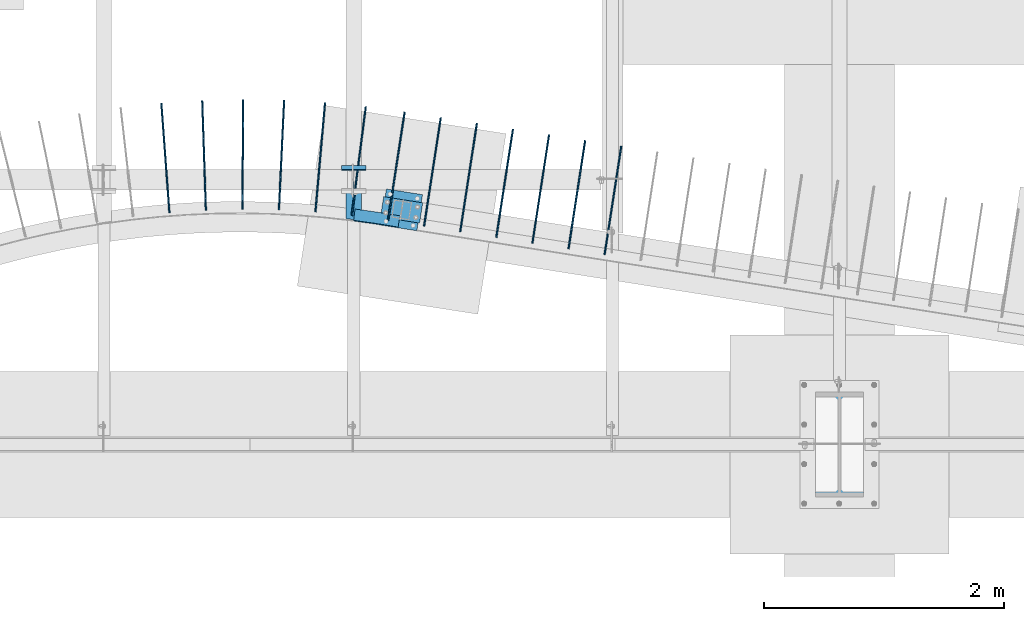
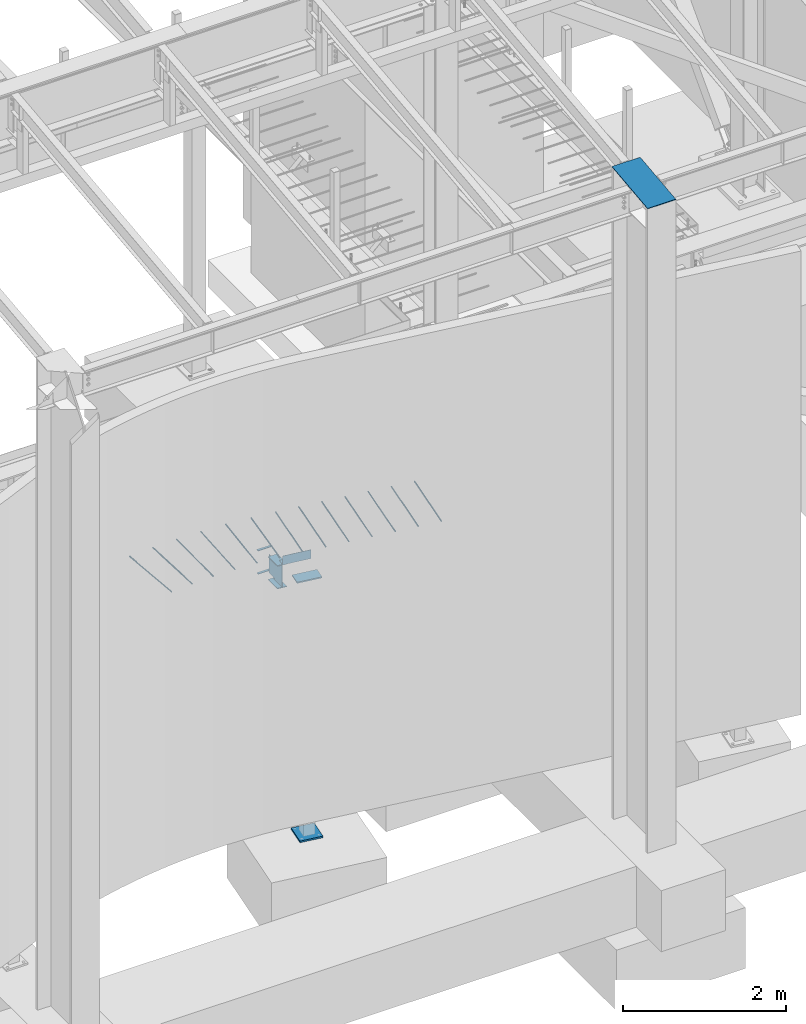
# One storey, part 813 of 1179: 20 beams, 18 elements without a shape of their own.
"""IFC2X3 building model written with IfcOpenShell, lengths in millimetres."""

from ifc_helpers import new_model, si_unit, frame, origin_with_axes, place, context, subcontext, project, spatial, faceted_brep, material, type_object, element, aggregate, save


model = new_model("IFC2X3")

# Units and contexts
model_context = context("Model", 3, precision=1e-05, world=origin_with_axes())
body_context = subcontext(model_context, "Body", "Model", "MODEL_VIEW")
ifc_project = project(units=[si_unit("LENGTHUNIT", "METRE", prefix="MILLI"), si_unit("AREAUNIT", "SQUARE_METRE"), si_unit("VOLUMEUNIT", "CUBIC_METRE"), si_unit("MASSUNIT", "GRAM", prefix="KILO"), si_unit("TIMEUNIT", "SECOND"), si_unit("PLANEANGLEUNIT", "RADIAN"), si_unit("SOLIDANGLEUNIT", "STERADIAN"), si_unit("THERMODYNAMICTEMPERATUREUNIT", "DEGREE_CELSIUS"), si_unit("LUMINOUSINTENSITYUNIT", "LUMEN")], contexts=[model_context])

# Site, building, storey
site_placement = place(None, origin_with_axes())
site = spatial("IfcSite", under=ifc_project, at=site_placement, CompositionType="ELEMENT")
building_placement = place(site_placement, origin_with_axes())
building = spatial("IfcBuilding", under=site, at=building_placement, Name="Undefined", CompositionType="ELEMENT")
storey_placement = place(building_placement, origin_with_axes())
storey = spatial("IfcBuildingStorey", under=building, at=storey_placement, Name="Undefined", CompositionType="ELEMENT", Elevation=0.0)

# Assembly, beams
assembly_1_placement = place(storey_placement, origin_with_axes())
assembly_1 = element("IfcElementAssembly", 1, at=assembly_1_placement, inside=storey, Name="BEAM", AssemblyPlace="NOTDEFINED", PredefinedType="RIGID_FRAME")
ifc_material_1 = material(Name="STEEL/A36")
beam_type_1 = type_object("IfcBeamType", PredefinedType="NOTDEFINED")
beam_1_placement = place(assembly_1_placement, frame((12407.9, 2733.675, 3831.8280002594), z_axis=(-1.0, 0.0, 0.0), x_axis=(0.0, 1.0, 0.0)))
beam_1 = element("IfcBeam", 2, at=beam_1_placement, type_object=beam_type_1, material=ifc_material_1, Name="PLATE", context=body_context, shape_type="Brep", body=[
    faceted_brep([(0.0, 4.76250000000073, -101.6), (0.0, 4.76250000000073, 101.6), (31.75, 4.76249999999982, 101.6), (31.75, 4.76249999999982, -101.6), (0.0, -4.76250000000073, 101.6), (31.75, -4.76249999999982, 101.6), (0.0, -4.76250000000073, -101.6), (31.75, -4.76249999999982, -101.6)], [[[0, 1, 2, 3]], [[1, 4, 5, 2]], [[4, 6, 7, 5]], [[6, 0, 3, 7]], [[5, 7, 3, 2]], [[6, 4, 1, 0]]]),
])
beam_2_placement = place(assembly_1_placement, frame((12407.9, 2722.56287437001, 3490.9125), z_axis=(-1.0, 0.0, 0.0), x_axis=(0.0, 1.0, 0.0)))
beam_2 = element("IfcBeam", 3, at=beam_2_placement, type_object=beam_type_1, material=ifc_material_1, Name="PLATE", context=body_context, shape_type="Brep", body=[
    faceted_brep([(0.0, 4.76250000000073, -101.6), (0.0, 4.76250000000073, 101.6), (31.75, 4.76249999999982, 101.6), (31.75, 4.76249999999982, -101.6), (0.0, -4.76250000000073, 101.6), (31.75, -4.76249999999982, 101.6), (0.0, -4.76250000000073, -101.6), (31.75, -4.76249999999982, -101.6)], [[[0, 1, 2, 3]], [[1, 4, 5, 2]], [[4, 6, 7, 5]], [[6, 0, 3, 7]], [[5, 7, 3, 2]], [[6, 4, 1, 0]]]),
])
aggregate(assembly_1, [beam_1, beam_2])

# Assembly, beam
assembly_2_placement = place(storey_placement, origin_with_axes())
assembly_2 = element("IfcElementAssembly", 4, at=assembly_2_placement, inside=storey, Name="COLUMN", AssemblyPlace="NOTDEFINED", PredefinedType="RIGID_FRAME")
beam_type_2 = type_object("IfcBeamType", PredefinedType="NOTDEFINED")
beam_3_placement = place(assembly_2_placement, frame((16459.2, 876.834752967023, 9341.1779874812), z_axis=(1.0, 0.0, 0.0), x_axis=(0.0, -0.993676146336441, -0.112284087038017)))
beam_3 = element("IfcBeam", 5, at=beam_3_placement, type_object=beam_type_2, material=ifc_material_1, Name="PLATE", context=body_context, shape_type="Brep", body=[
    faceted_brep([(1.07631237348505, 4.76249999999709, -200.025), (1.07631237348505, 4.76249999999709, 200.025), (882.953172586766, 4.762499999586, 200.025), (882.953172586766, 4.762499999586, -200.025), (2.52225618169177e-09, -4.76249999999709, 200.025), (881.876860215802, -4.76250000041, 200.025), (2.52225618169177e-09, -4.76249999999709, -200.025), (881.876860215802, -4.76250000041, -200.025)], [[[0, 1, 2, 3]], [[1, 4, 5, 2]], [[4, 6, 7, 5]], [[6, 0, 3, 7]], [[5, 7, 3, 2]], [[6, 4, 1, 0]]]),
])
aggregate(assembly_2, [beam_3])

assembly_3_placement = place(storey_placement, origin_with_axes())
assembly_3 = element("IfcElementAssembly", 6, at=assembly_3_placement, inside=storey, Name="COLUMN", AssemblyPlace="NOTDEFINED", PredefinedType="RIGID_FRAME")
beam_type_3 = type_object("IfcBeamType", PredefinedType="NOTDEFINED")
beam_4_placement = place(assembly_3_placement, frame((12644.5759112125, 2421.41210607514, 3479.8), z_axis=(-0.156378291007964, -0.987697236050313, 0.0), x_axis=(0.987697236050313, -0.156378291007965, 0.0)))
beam_4 = element("IfcBeam", 7, at=beam_4_placement, type_object=beam_type_3, material=ifc_material_1, Name="PLATE", context=body_context, shape_type="Brep", body=[
    faceted_brep([(-7.27595761418343e-11, 9.52500000000009, -85.7249999999858), (7.82165443524718e-11, 9.52500000000009, 85.724999999984), (330.199999998111, 9.52500000000009, 85.7249999999631), (330.199999997958, 9.52500000000009, -85.7250000000067), (7.82165443524718e-11, -9.52500000000009, 85.724999999984), (330.199999998111, -9.52500000000009, 85.7249999999631), (-7.27595761418343e-11, -9.52500000000009, -85.7249999999858), (330.199999997958, -9.52500000000009, -85.7250000000067)], [[[0, 1, 2, 3]], [[1, 4, 5, 2]], [[4, 6, 7, 5]], [[6, 0, 3, 7]], [[5, 7, 3, 2]], [[6, 4, 1, 0]]]),
])

assembly_4_placement = place(storey_placement, origin_with_axes())
assembly_4 = element("IfcElementAssembly", 8, at=assembly_4_placement, inside=storey, Name="#4 DOWEL", AssemblyPlace="NOTDEFINED", PredefinedType="NOTDEFINED")
ifc_material_2 = material(Name="REBAR/A615-40")
beam_type_4 = type_object("IfcBeamType", Name="#4 DOWEL", PredefinedType="NOTDEFINED")
beam_5_placement = place(assembly_4_placement, frame((14500.3334740278, 2022.55347503947, 3943.35000610352), z_axis=(-0.988373645766026, 0.152044520964006, 0.0), x_axis=(0.152044520964006, 0.988373645766026, 0.0)))
beam_5 = element("IfcBeam", 9, at=beam_5_placement, type_object=beam_type_4, material=ifc_material_2, Name="#4 DOWEL", ObjectType="#4 DOWEL", context=body_context, shape_type="Brep", body=[
    faceted_brep([(0.0, -6.34999999999854, 0.0), (0.0, -4.49012806053361, -4.49012806053452), (914.399999999994, -4.49012806053452, -4.49012806042992), (914.399999999994, -6.34999999999991, 1.0550138540566e-10), (0.0, 0.0, -6.34999999999991), (914.399999999994, 0.0, -6.34999999989668), (0.0, 4.49012806053361, -4.49012806053452), (914.399999999994, 4.49012806053452, -4.49012806042992), (0.0, 6.34999999999854, 0.0), (914.399999999994, 6.34999999999991, 1.0550138540566e-10), (0.0, 4.49012806053361, 4.49012806053452), (914.399999999995, 4.49012806053452, 4.49012806064184), (0.0, 0.0, 6.34999999999991), (914.399999999995, 0.0, 6.35000000010768), (0.0, -4.49012806053361, 4.49012806053452), (914.399999999995, -4.49012806053452, 4.49012806064184)], [[[0, 1, 2, 3]], [[1, 4, 5, 2]], [[4, 6, 7, 5]], [[6, 8, 9, 7]], [[8, 10, 11, 9]], [[10, 12, 13, 11]], [[12, 14, 15, 13]], [[14, 0, 3, 15]], [[5, 7, 9, 11, 13, 15, 3, 2]], [[14, 12, 10, 8, 6, 4, 1, 0]]]),
])
aggregate(assembly_4, [beam_5])

assembly_5_placement = place(storey_placement, origin_with_axes())
assembly_5 = element("IfcElementAssembly", 10, at=assembly_5_placement, inside=storey, Name="#4 DOWEL", AssemblyPlace="NOTDEFINED", PredefinedType="NOTDEFINED")
beam_6_placement = place(assembly_5_placement, frame((14199.2720604806, 2070.14617692751, 3943.35000610352), z_axis=(-0.988373645766026, 0.152044520964006, 0.0), x_axis=(0.152044520964006, 0.988373645766026, 0.0)))
beam_6 = element("IfcBeam", 11, at=beam_6_placement, type_object=beam_type_4, material=ifc_material_2, Name="#4 DOWEL", ObjectType="#4 DOWEL", context=body_context, shape_type="Brep", body=[
    faceted_brep([(0.0, -6.34999999999854, 0.0), (0.0, -4.49012806053361, -4.49012806053452), (914.399999999994, -4.49012806053452, -4.49012806042992), (914.399999999994, -6.34999999999991, 1.0550138540566e-10), (0.0, 0.0, -6.34999999999991), (914.399999999994, 0.0, -6.34999999989668), (0.0, 4.49012806053361, -4.49012806053452), (914.399999999994, 4.49012806053452, -4.49012806042992), (0.0, 6.34999999999854, 0.0), (914.399999999994, 6.34999999999991, 1.0550138540566e-10), (0.0, 4.49012806053361, 4.49012806053452), (914.399999999995, 4.49012806053452, 4.49012806064184), (0.0, 0.0, 6.34999999999991), (914.399999999995, 0.0, 6.35000000010768), (0.0, -4.49012806053361, 4.49012806053452), (914.399999999995, -4.49012806053452, 4.49012806064184)], [[[0, 1, 2, 3]], [[1, 4, 5, 2]], [[4, 6, 7, 5]], [[6, 8, 9, 7]], [[8, 10, 11, 9]], [[10, 12, 13, 11]], [[12, 14, 15, 13]], [[14, 0, 3, 15]], [[5, 7, 9, 11, 13, 15, 3, 2]], [[14, 12, 10, 8, 6, 4, 1, 0]]]),
])
aggregate(assembly_5, [beam_6])

assembly_6_placement = place(storey_placement, origin_with_axes())
assembly_6 = element("IfcElementAssembly", 12, at=assembly_6_placement, inside=storey, Name="#4 DOWEL", AssemblyPlace="NOTDEFINED", PredefinedType="NOTDEFINED")
beam_7_placement = place(assembly_6_placement, frame((13898.2106469335, 2117.73887881554, 3943.35000610352), z_axis=(-0.988373645766026, 0.152044520964006, 0.0), x_axis=(0.152044520964006, 0.988373645766026, 0.0)))
beam_7 = element("IfcBeam", 13, at=beam_7_placement, type_object=beam_type_4, material=ifc_material_2, Name="#4 DOWEL", ObjectType="#4 DOWEL", context=body_context, shape_type="Brep", body=[
    faceted_brep([(0.0, -6.34999999999854, 0.0), (0.0, -4.49012806053361, -4.49012806053452), (914.399999999994, -4.49012806053452, -4.49012806042992), (914.399999999994, -6.34999999999991, 1.0550138540566e-10), (0.0, 0.0, -6.34999999999991), (914.399999999994, 0.0, -6.34999999989668), (0.0, 4.49012806053361, -4.49012806053452), (914.399999999994, 4.49012806053452, -4.49012806042992), (0.0, 6.34999999999854, 0.0), (914.399999999994, 6.34999999999991, 1.0550138540566e-10), (0.0, 4.49012806053361, 4.49012806053452), (914.399999999995, 4.49012806053452, 4.49012806064184), (0.0, 0.0, 6.34999999999991), (914.399999999995, 0.0, 6.35000000010768), (0.0, -4.49012806053361, 4.49012806053452), (914.399999999995, -4.49012806053452, 4.49012806064184)], [[[0, 1, 2, 3]], [[1, 4, 5, 2]], [[4, 6, 7, 5]], [[6, 8, 9, 7]], [[8, 10, 11, 9]], [[10, 12, 13, 11]], [[12, 14, 15, 13]], [[14, 0, 3, 15]], [[5, 7, 9, 11, 13, 15, 3, 2]], [[14, 12, 10, 8, 6, 4, 1, 0]]]),
])
aggregate(assembly_6, [beam_7])

assembly_7_placement = place(storey_placement, origin_with_axes())
assembly_7 = element("IfcElementAssembly", 14, at=assembly_7_placement, inside=storey, Name="#4 DOWEL", AssemblyPlace="NOTDEFINED", PredefinedType="NOTDEFINED")
beam_8_placement = place(assembly_7_placement, frame((13597.1492333864, 2165.33158070358, 3943.35000610352), z_axis=(-0.988373645766026, 0.152044520964006, 0.0), x_axis=(0.152044520964006, 0.988373645766026, 0.0)))
beam_8 = element("IfcBeam", 15, at=beam_8_placement, type_object=beam_type_4, material=ifc_material_2, Name="#4 DOWEL", ObjectType="#4 DOWEL", context=body_context, shape_type="Brep", body=[
    faceted_brep([(0.0, -6.34999999999854, 0.0), (0.0, -4.49012806053361, -4.49012806053452), (914.399999999994, -4.49012806053452, -4.49012806042992), (914.399999999994, -6.34999999999991, 1.0550138540566e-10), (0.0, 0.0, -6.34999999999991), (914.399999999994, 0.0, -6.34999999989668), (0.0, 4.49012806053361, -4.49012806053452), (914.399999999994, 4.49012806053452, -4.49012806042992), (0.0, 6.34999999999854, 0.0), (914.399999999994, 6.34999999999991, 1.0550138540566e-10), (0.0, 4.49012806053361, 4.49012806053452), (914.399999999995, 4.49012806053452, 4.49012806064184), (0.0, 0.0, 6.34999999999991), (914.399999999995, 0.0, 6.35000000010768), (0.0, -4.49012806053361, 4.49012806053452), (914.399999999995, -4.49012806053452, 4.49012806064184)], [[[0, 1, 2, 3]], [[1, 4, 5, 2]], [[4, 6, 7, 5]], [[6, 8, 9, 7]], [[8, 10, 11, 9]], [[10, 12, 13, 11]], [[12, 14, 15, 13]], [[14, 0, 3, 15]], [[5, 7, 9, 11, 13, 15, 3, 2]], [[14, 12, 10, 8, 6, 4, 1, 0]]]),
])
aggregate(assembly_7, [beam_8])

assembly_8_placement = place(storey_placement, origin_with_axes())
assembly_8 = element("IfcElementAssembly", 16, at=assembly_8_placement, inside=storey, Name="#4 DOWEL", AssemblyPlace="NOTDEFINED", PredefinedType="NOTDEFINED")
beam_9_placement = place(assembly_8_placement, frame((13296.0878198392, 2212.92428259161, 3943.35000610352), z_axis=(-0.988373645766026, 0.152044520964006, 0.0), x_axis=(0.152044520964006, 0.988373645766026, 0.0)))
beam_9 = element("IfcBeam", 17, at=beam_9_placement, type_object=beam_type_4, material=ifc_material_2, Name="#4 DOWEL", ObjectType="#4 DOWEL", context=body_context, shape_type="Brep", body=[
    faceted_brep([(0.0, -6.34999999999854, 0.0), (0.0, -4.49012806053361, -4.49012806053452), (914.399999999994, -4.49012806053452, -4.49012806042992), (914.399999999994, -6.34999999999991, 1.0550138540566e-10), (0.0, 0.0, -6.34999999999991), (914.399999999994, 0.0, -6.34999999989668), (0.0, 4.49012806053361, -4.49012806053452), (914.399999999994, 4.49012806053452, -4.49012806042992), (0.0, 6.34999999999854, 0.0), (914.399999999994, 6.34999999999991, 1.0550138540566e-10), (0.0, 4.49012806053361, 4.49012806053452), (914.399999999995, 4.49012806053452, 4.49012806064184), (0.0, 0.0, 6.34999999999991), (914.399999999995, 0.0, 6.35000000010768), (0.0, -4.49012806053361, 4.49012806053452), (914.399999999995, -4.49012806053452, 4.49012806064184)], [[[0, 1, 2, 3]], [[1, 4, 5, 2]], [[4, 6, 7, 5]], [[6, 8, 9, 7]], [[8, 10, 11, 9]], [[10, 12, 13, 11]], [[12, 14, 15, 13]], [[14, 0, 3, 15]], [[5, 7, 9, 11, 13, 15, 3, 2]], [[14, 12, 10, 8, 6, 4, 1, 0]]]),
])
aggregate(assembly_8, [beam_9])

assembly_9_placement = place(storey_placement, origin_with_axes())
assembly_9 = element("IfcElementAssembly", 18, at=assembly_9_placement, inside=storey, Name="#4 DOWEL", AssemblyPlace="NOTDEFINED", PredefinedType="NOTDEFINED")
beam_10_placement = place(assembly_9_placement, frame((12995.0264062921, 2260.51698447965, 3943.35000610352), z_axis=(-0.988373645766026, 0.152044520964006, 0.0), x_axis=(0.152044520964006, 0.988373645766026, 0.0)))
beam_10 = element("IfcBeam", 19, at=beam_10_placement, type_object=beam_type_4, material=ifc_material_2, Name="#4 DOWEL", ObjectType="#4 DOWEL", context=body_context, shape_type="Brep", body=[
    faceted_brep([(0.0, -6.34999999999854, 0.0), (0.0, -4.49012806053361, -4.49012806053452), (914.399999999994, -4.49012806053452, -4.49012806042992), (914.399999999994, -6.34999999999991, 1.0550138540566e-10), (0.0, 0.0, -6.34999999999991), (914.399999999994, 0.0, -6.34999999989668), (0.0, 4.49012806053361, -4.49012806053452), (914.399999999994, 4.49012806053452, -4.49012806042992), (0.0, 6.34999999999854, 0.0), (914.399999999994, 6.34999999999991, 1.0550138540566e-10), (0.0, 4.49012806053361, 4.49012806053452), (914.399999999995, 4.49012806053452, 4.49012806064184), (0.0, 0.0, 6.34999999999991), (914.399999999995, 0.0, 6.35000000010768), (0.0, -4.49012806053361, 4.49012806053452), (914.399999999995, -4.49012806053452, 4.49012806064184)], [[[0, 1, 2, 3]], [[1, 4, 5, 2]], [[4, 6, 7, 5]], [[6, 8, 9, 7]], [[8, 10, 11, 9]], [[10, 12, 13, 11]], [[12, 14, 15, 13]], [[14, 0, 3, 15]], [[5, 7, 9, 11, 13, 15, 3, 2]], [[14, 12, 10, 8, 6, 4, 1, 0]]]),
])
aggregate(assembly_9, [beam_10])

assembly_10_placement = place(storey_placement, origin_with_axes())
assembly_10 = element("IfcElementAssembly", 20, at=assembly_10_placement, inside=storey, Name="#4 DOWEL", AssemblyPlace="NOTDEFINED", PredefinedType="NOTDEFINED")
beam_11_placement = place(assembly_10_placement, frame((12693.9078592994, 2307.731470209, 3943.35000610352), z_axis=(-0.988373645766026, 0.152044520964006, 0.0), x_axis=(0.152044520964006, 0.988373645766026, 0.0)))
beam_11 = element("IfcBeam", 21, at=beam_11_placement, type_object=beam_type_4, material=ifc_material_2, Name="#4 DOWEL", ObjectType="#4 DOWEL", context=body_context, shape_type="Brep", body=[
    faceted_brep([(0.0, -6.34999999999854, 0.0), (0.0, -4.49012806053361, -4.49012806053452), (914.399999999994, -4.49012806053452, -4.49012806042992), (914.399999999994, -6.34999999999991, 1.0550138540566e-10), (0.0, 0.0, -6.34999999999991), (914.399999999994, 0.0, -6.34999999989668), (0.0, 4.49012806053361, -4.49012806053452), (914.399999999994, 4.49012806053452, -4.49012806042992), (0.0, 6.34999999999854, 0.0), (914.399999999994, 6.34999999999991, 1.0550138540566e-10), (0.0, 4.49012806053361, 4.49012806053452), (914.399999999995, 4.49012806053452, 4.49012806064184), (0.0, 0.0, 6.34999999999991), (914.399999999995, 0.0, 6.35000000010768), (0.0, -4.49012806053361, 4.49012806053452), (914.399999999995, -4.49012806053452, 4.49012806064184)], [[[0, 1, 2, 3]], [[1, 4, 5, 2]], [[4, 6, 7, 5]], [[6, 8, 9, 7]], [[8, 10, 11, 9]], [[10, 12, 13, 11]], [[12, 14, 15, 13]], [[14, 0, 3, 15]], [[5, 7, 9, 11, 13, 15, 3, 2]], [[14, 12, 10, 8, 6, 4, 1, 0]]]),
])
aggregate(assembly_10, [beam_11])

assembly_11_placement = place(storey_placement, origin_with_axes())
assembly_11 = element("IfcElementAssembly", 22, at=assembly_11_placement, inside=storey, Name="#4 DOWEL", AssemblyPlace="NOTDEFINED", PredefinedType="NOTDEFINED")
beam_12_placement = place(assembly_11_placement, frame((12391.9260624311, 2348.96965486784, 3943.35000610352), z_axis=(-0.991828533896501, 0.127578051986687, 0.0), x_axis=(0.127578051986688, 0.991828533896501, 0.0)))
beam_12 = element("IfcBeam", 23, at=beam_12_placement, type_object=beam_type_4, material=ifc_material_2, Name="#4 DOWEL", ObjectType="#4 DOWEL", context=body_context, shape_type="Brep", body=[
    faceted_brep([(0.0, -6.34999999999854, 0.0), (0.0, -4.49012806053361, -4.49012806053452), (914.399999999994, -4.49012806053452, -4.49012806042992), (914.399999999994, -6.34999999999991, 1.0550138540566e-10), (0.0, 0.0, -6.34999999999991), (914.399999999994, 0.0, -6.34999999989668), (0.0, 4.49012806053361, -4.49012806053452), (914.399999999994, 4.49012806053452, -4.49012806042992), (0.0, 6.34999999999854, 0.0), (914.399999999994, 6.34999999999991, 1.0550138540566e-10), (0.0, 4.49012806053361, 4.49012806053452), (914.399999999995, 4.49012806053452, 4.49012806064184), (0.0, 0.0, 6.34999999999991), (914.399999999995, 0.0, 6.35000000010768), (0.0, -4.49012806053361, 4.49012806053452), (914.399999999995, -4.49012806053452, 4.49012806064184)], [[[0, 1, 2, 3]], [[1, 4, 5, 2]], [[4, 6, 7, 5]], [[6, 8, 9, 7]], [[8, 10, 11, 9]], [[10, 12, 13, 11]], [[12, 14, 15, 13]], [[14, 0, 3, 15]], [[5, 7, 9, 11, 13, 15, 3, 2]], [[14, 12, 10, 8, 6, 4, 1, 0]]]),
])
aggregate(assembly_11, [beam_12])

assembly_12_placement = place(storey_placement, origin_with_axes())
assembly_12 = element("IfcElementAssembly", 24, at=assembly_12_placement, inside=storey, Name="#4 DOWEL", AssemblyPlace="NOTDEFINED", PredefinedType="NOTDEFINED")
beam_13_placement = place(assembly_12_placement, frame((12088.5944641768, 2378.34830935244, 3943.35000610352), z_axis=(-0.996166399109763, 0.0874785990096393, 0.0), x_axis=(0.0874785990096393, 0.996166399109763, 0.0)))
beam_13 = element("IfcBeam", 25, at=beam_13_placement, type_object=beam_type_4, material=ifc_material_2, Name="#4 DOWEL", ObjectType="#4 DOWEL", context=body_context, shape_type="Brep", body=[
    faceted_brep([(0.0, -6.34999999999854, 0.0), (0.0, -4.49012806053361, -4.49012806053452), (914.399999999994, -4.49012806053452, -4.49012806042992), (914.399999999994, -6.34999999999991, 1.0550138540566e-10), (0.0, 0.0, -6.34999999999991), (914.399999999994, 0.0, -6.34999999989668), (0.0, 4.49012806053361, -4.49012806053452), (914.399999999994, 4.49012806053452, -4.49012806042992), (0.0, 6.34999999999854, 0.0), (914.399999999994, 6.34999999999991, 1.0550138540566e-10), (0.0, 4.49012806053361, 4.49012806053452), (914.399999999995, 4.49012806053452, 4.49012806064184), (0.0, 0.0, 6.34999999999991), (914.399999999995, 0.0, 6.35000000010768), (0.0, -4.49012806053361, 4.49012806053452), (914.399999999995, -4.49012806053452, 4.49012806064184)], [[[0, 1, 2, 3]], [[1, 4, 5, 2]], [[4, 6, 7, 5]], [[6, 8, 9, 7]], [[8, 10, 11, 9]], [[10, 12, 13, 11]], [[12, 14, 15, 13]], [[14, 0, 3, 15]], [[5, 7, 9, 11, 13, 15, 3, 2]], [[14, 12, 10, 8, 6, 4, 1, 0]]]),
])
aggregate(assembly_12, [beam_13])

assembly_13_placement = place(storey_placement, origin_with_axes())
assembly_13 = element("IfcElementAssembly", 26, at=assembly_13_placement, inside=storey, Name="#4 DOWEL", AssemblyPlace="NOTDEFINED", PredefinedType="NOTDEFINED")
beam_14_placement = place(assembly_13_placement, frame((11784.3416047818, 2395.91658469593, 3943.35000610352), z_axis=(-0.998883717525659, 0.047236837977568, 0.0), x_axis=(0.0472368379775682, 0.998883717525659, 0.0)))
beam_14 = element("IfcBeam", 27, at=beam_14_placement, type_object=beam_type_4, material=ifc_material_2, Name="#4 DOWEL", ObjectType="#4 DOWEL", context=body_context, shape_type="Brep", body=[
    faceted_brep([(0.0, -6.34999999999854, 0.0), (0.0, -4.49012806053361, -4.49012806053452), (914.399999999994, -4.49012806053452, -4.49012806042992), (914.399999999994, -6.34999999999991, 1.0550138540566e-10), (0.0, 0.0, -6.34999999999991), (914.399999999994, 0.0, -6.34999999989668), (0.0, 4.49012806053361, -4.49012806053452), (914.399999999994, 4.49012806053452, -4.49012806042992), (0.0, 6.34999999999854, 0.0), (914.399999999994, 6.34999999999991, 1.0550138540566e-10), (0.0, 4.49012806053361, 4.49012806053452), (914.399999999995, 4.49012806053452, 4.49012806064184), (0.0, 0.0, 6.34999999999991), (914.399999999995, 0.0, 6.35000000010768), (0.0, -4.49012806053361, 4.49012806053452), (914.399999999995, -4.49012806053452, 4.49012806064184)], [[[0, 1, 2, 3]], [[1, 4, 5, 2]], [[4, 6, 7, 5]], [[6, 8, 9, 7]], [[8, 10, 11, 9]], [[10, 12, 13, 11]], [[12, 14, 15, 13]], [[14, 0, 3, 15]], [[5, 7, 9, 11, 13, 15, 3, 2]], [[14, 12, 10, 8, 6, 4, 1, 0]]]),
])
aggregate(assembly_13, [beam_14])

assembly_14_placement = place(storey_placement, origin_with_axes())
assembly_14 = element("IfcElementAssembly", 28, at=assembly_14_placement, inside=storey, Name="#4 DOWEL", AssemblyPlace="NOTDEFINED", PredefinedType="NOTDEFINED")
beam_15_placement = place(assembly_14_placement, frame((11479.5828312659, 2401.60508093322, 3943.35000610352), z_axis=(-0.999976068739739, 0.00691823299819862, 0.0), x_axis=(0.00691823299819853, 0.999976068739739, 0.0)))
beam_15 = element("IfcBeam", 29, at=beam_15_placement, type_object=beam_type_4, material=ifc_material_2, Name="#4 DOWEL", ObjectType="#4 DOWEL", context=body_context, shape_type="Brep", body=[
    faceted_brep([(0.0, -6.34999999999854, 0.0), (0.0, -4.49012806053361, -4.49012806053452), (914.399999999994, -4.49012806053452, -4.49012806042992), (914.399999999994, -6.34999999999991, 1.0550138540566e-10), (0.0, 0.0, -6.34999999999991), (914.399999999994, 0.0, -6.34999999989668), (0.0, 4.49012806053361, -4.49012806053452), (914.399999999994, 4.49012806053452, -4.49012806042992), (0.0, 6.34999999999854, 0.0), (914.399999999994, 6.34999999999991, 1.0550138540566e-10), (0.0, 4.49012806053361, 4.49012806053452), (914.399999999995, 4.49012806053452, 4.49012806064184), (0.0, 0.0, 6.34999999999991), (914.399999999995, 0.0, 6.35000000010768), (0.0, -4.49012806053361, 4.49012806053452), (914.399999999995, -4.49012806053452, 4.49012806064184)], [[[0, 1, 2, 3]], [[1, 4, 5, 2]], [[4, 6, 7, 5]], [[6, 8, 9, 7]], [[8, 10, 11, 9]], [[10, 12, 13, 11]], [[12, 14, 15, 13]], [[14, 0, 3, 15]], [[5, 7, 9, 11, 13, 15, 3, 2]], [[14, 12, 10, 8, 6, 4, 1, 0]]]),
])
aggregate(assembly_14, [beam_15])

assembly_15_placement = place(storey_placement, origin_with_axes())
assembly_15 = element("IfcElementAssembly", 30, at=assembly_15_placement, inside=storey, Name="#4 DOWEL", AssemblyPlace="NOTDEFINED", PredefinedType="NOTDEFINED")
beam_16_placement = place(assembly_15_placement, frame((11174.9204516641, 2393.20585654861, 3943.35000610352), z_axis=(-0.999441675727914, -0.0334116269909036, 0.0), x_axis=(-0.0334116269909036, 0.999441675727914, 0.0)))
beam_16 = element("IfcBeam", 31, at=beam_16_placement, type_object=beam_type_4, material=ifc_material_2, Name="#4 DOWEL", ObjectType="#4 DOWEL", context=body_context, shape_type="Brep", body=[
    faceted_brep([(0.0, -6.34999999999854, 0.0), (0.0, -4.49012806053361, -4.49012806053452), (914.399999999994, -4.49012806053452, -4.49012806042992), (914.399999999994, -6.34999999999991, 1.0550138540566e-10), (0.0, 0.0, -6.34999999999991), (914.399999999994, 0.0, -6.34999999989668), (0.0, 4.49012806053361, -4.49012806053452), (914.399999999994, 4.49012806053452, -4.49012806042992), (0.0, 6.34999999999854, 0.0), (914.399999999994, 6.34999999999991, 1.0550138540566e-10), (0.0, 4.49012806053361, 4.49012806053452), (914.399999999995, 4.49012806053452, 4.49012806064184), (0.0, 0.0, 6.34999999999991), (914.399999999995, 0.0, 6.35000000010768), (0.0, -4.49012806053361, 4.49012806053452), (914.399999999995, -4.49012806053452, 4.49012806064184)], [[[0, 1, 2, 3]], [[1, 4, 5, 2]], [[4, 6, 7, 5]], [[6, 8, 9, 7]], [[8, 10, 11, 9]], [[10, 12, 13, 11]], [[12, 14, 15, 13]], [[14, 0, 3, 15]], [[5, 7, 9, 11, 13, 15, 3, 2]], [[14, 12, 10, 8, 6, 4, 1, 0]]]),
])
aggregate(assembly_15, [beam_16])

assembly_16_placement = place(storey_placement, origin_with_axes())
assembly_16 = element("IfcElementAssembly", 32, at=assembly_16_placement, inside=storey, Name="#4 DOWEL", AssemblyPlace="NOTDEFINED", PredefinedType="NOTDEFINED")
beam_17_placement = place(assembly_16_placement, frame((10870.822431373, 2373.02333196561, 3943.35000610352), z_axis=(-0.997281407844313, -0.0736871329884975, 0.0), x_axis=(-0.0736871329884975, 0.997281407844313, 0.0)))
beam_17 = element("IfcBeam", 33, at=beam_17_placement, type_object=beam_type_4, material=ifc_material_2, Name="#4 DOWEL", ObjectType="#4 DOWEL", context=body_context, shape_type="Brep", body=[
    faceted_brep([(0.0, -6.34999999999854, 0.0), (0.0, -4.49012806053361, -4.49012806053452), (914.399999999994, -4.49012806053452, -4.49012806042992), (914.399999999994, -6.34999999999991, 1.0550138540566e-10), (0.0, 0.0, -6.34999999999991), (914.399999999994, 0.0, -6.34999999989668), (0.0, 4.49012806053361, -4.49012806053452), (914.399999999994, 4.49012806053452, -4.49012806042992), (0.0, 6.34999999999854, 0.0), (914.399999999994, 6.34999999999991, 1.0550138540566e-10), (0.0, 4.49012806053361, 4.49012806053452), (914.399999999995, 4.49012806053452, 4.49012806064184), (0.0, 0.0, 6.34999999999991), (914.399999999995, 0.0, 6.35000000010768), (0.0, -4.49012806053361, 4.49012806053452), (914.399999999995, -4.49012806053452, 4.49012806064184)], [[[0, 1, 2, 3]], [[1, 4, 5, 2]], [[4, 6, 7, 5]], [[6, 8, 9, 7]], [[8, 10, 11, 9]], [[10, 12, 13, 11]], [[12, 14, 15, 13]], [[14, 0, 3, 15]], [[5, 7, 9, 11, 13, 15, 3, 2]], [[14, 12, 10, 8, 6, 4, 1, 0]]]),
])
aggregate(assembly_16, [beam_17])

# Beam
ifc_material_3 = material(Name="STEEL/A572-GR.50")
beam_type_5 = type_object("IfcBeamType", PredefinedType="NOTDEFINED")
beam_18_placement = place(assembly_3_placement, frame((12657.1556151928, 2419.06454316718, -368.299999999999), z_axis=(0.154376895068654, 0.988012031439376, 0.0), x_axis=(0.988012031439376, -0.154376895068652, 0.0)))
beam_18 = element("IfcBeam", 34, at=beam_18_placement, type_object=beam_type_5, material=ifc_material_3, context=body_context, shape_type="Brep", body=[
    faceted_brep([(-7.27595761418343e-12, 12.7, -152.400000000011), (7.27595761418343e-12, 12.7, 152.400000000011), (304.800000000494, 12.7, 152.400000000071), (304.800000000479, 12.7, -152.39999999995), (7.27595761418343e-12, -12.7, 152.400000000011), (304.800000000494, -12.7, 152.400000000071), (-7.27595761418343e-12, -12.7, -152.400000000011), (304.800000000479, -12.7, -152.39999999995)], [[[0, 1, 2, 3]], [[1, 4, 5, 2]], [[4, 6, 7, 5]], [[6, 0, 3, 7]], [[5, 7, 3, 2]], [[6, 4, 1, 0]]]),
])

aggregate(assembly_3, [beam_4, beam_18])

# Assembly, beam
assembly_17_placement = place(storey_placement, origin_with_axes())
assembly_17 = element("IfcElementAssembly", 35, at=assembly_17_placement, inside=storey, Name="BEAM", AssemblyPlace="NOTDEFINED", PredefinedType="RIGID_FRAME")
beam_type_6 = type_object("IfcBeamType", PredefinedType="NOTDEFINED")
beam_19_placement = place(assembly_17_placement, frame((12785.5195405369, 2296.17759038158, 3914.775), z_axis=(0.0, 0.0, 1.0), x_axis=(-0.987116697128316, 0.160001957020797, 0.0)))
beam_19 = element("IfcBeam", 36, at=beam_19_placement, type_object=beam_type_6, material=ifc_material_1, Name="BENT_PLATE", context=body_context, shape_type="Brep", body=[
    faceted_brep([(187.599019790676, 50.8007315047262, 66.6750000000002), (375.146787586247, 55.1855947390641, 66.6750000000002), (375.146787586247, 55.1855947390641, -66.6750000000002), (187.599019790676, 50.8007315047262, -66.6750000000002), (375.369383347594, 48.8394974244102, 66.6750000000002), (375.369383347594, 48.8394974244102, -60.3249999999998), (378.708319767798, -46.3519622953809, -60.3249999999998), (378.708319767798, -46.3519622953809, -66.6750000000002), (188.786677518714, -50.7923266691696, -66.6750000000002), (188.786677518714, -50.7923266691696, -60.3249999999998), (0.39693984769292, -50.7930612571326, -60.3249999999998), (0.39693984769292, -50.7930612571326, -66.6750000000002), (6.91215973347425e-11, 50.8000000000129, -66.6750000000002), (6.91215973347425e-11, 50.8000000000129, 66.6750000000002), (187.673248398678, 44.4511653688569, 66.6750000000002), (-0.0741791002219543, 44.4504332854549, 66.6750000000002), (187.673248398678, 44.4511653688569, -60.3249999999998), (-0.0741791002219543, 44.4504332854549, -60.3249999999998)], [[[0, 1, 2, 3]], [[4, 5, 6, 7, 2, 1]], [[8, 7, 6, 9]], [[8, 9, 10, 11]], [[3, 2, 7, 8, 11, 12]], [[0, 3, 12, 13]], [[14, 4, 1, 0, 13, 15]], [[16, 5, 4, 14]], [[15, 17, 16, 14]], [[9, 6, 5, 16, 17, 10]], [[15, 13, 12, 11, 10, 17]]]),
])
aggregate(assembly_17, [beam_19])

assembly_18_placement = place(storey_placement, origin_with_axes())
assembly_18 = element("IfcElementAssembly", 37, at=assembly_18_placement, inside=storey, Name="BEAM", AssemblyPlace="NOTDEFINED", PredefinedType="RIGID_FRAME")
ifc_material_4 = material(Name="STEEL/A992")
beam_type_7 = type_object("IfcBeamType", Name="W14X26", PredefinedType="NOTDEFINED")
beam_20_placement = place(assembly_18_placement, frame((12407.9, 2314.22945990653, 3671.8875), z_axis=(0.0, 0.0, 1.0), x_axis=(0.0, 1.0, 0.0)))
beam_20 = element("IfcBeam", 38, at=beam_20_placement, type_object=beam_type_7, material=ifc_material_4, Name="BEAM", ObjectType="W14X26", context=body_context, shape_type="Brep", body=[
    faceted_brep([(238.470551686471, -63.5, 165.1), (238.470551686471, -3.17499999999927, 165.1), (238.699752588355, -3.17499999999927, 164.703000259399), (238.699752588355, 3.17499999999927, 164.703000259399), (238.470551686471, 3.17499999999927, 165.1), (238.470551686471, 63.5, 165.1), (232.054942904633, 63.5, 176.2125), (232.054942904633, -63.5, 176.2125), (7.73801897871181, 63.5, -165.1), (0.386900948935363, 3.17499999999927, -165.1), (232.054917417016, 3.17499999999927, -165.1), (232.054917417016, 63.5, -165.1), (199.916505563083, -3.17499999999927, 158.045004848507), (199.916505563083, 3.17499999999927, 158.045004848507), (216.245543145227, 3.17499999999927, 164.703000259399), (216.245543145227, -3.17499999999927, 164.703000259399), (195.831766498712, -3.17499999999927, 154.857742002601), (195.831766498712, 3.17499999999927, 154.857742002601), (194.019669676741, -3.17499999999927, 150.003873155928), (194.019669676741, 3.17499999999927, 150.003873155928), (195.016375147024, -3.17499999999927, 144.919552564306), (195.016375147024, 3.17499999999927, 144.919552564306), (198.526979431912, -3.17499999999927, 141.10912014425), (198.526979431912, 3.17499999999927, 141.10912014425), (203.512771053307, -3.17499999999927, 139.7), (203.512771053307, 3.17499999999927, 139.7), (317.845540093473, -3.17499999999927, 139.7), (317.845540093473, 3.17499999999927, 139.7), (317.845540093473, -3.17499999999927, -139.7), (317.845540093473, 3.17499999999927, -139.7), (317.845540093473, 3.17499999999927, -92.4874999999993), (317.845540093473, 3.17499999999927, 138.112500000001), (196.638767147299, -3.17499999999927, -139.7), (196.638767147299, 3.17499999999927, -139.7), (191.652975525905, -3.17499999999927, -141.10912014425), (191.652975525905, 3.17499999999927, -141.10912014425), (188.142371241017, -3.17499999999927, -144.919552564306), (188.142371241017, 3.17499999999927, -144.919552564306), (187.145665770734, -3.17499999999927, -150.003873155929), (187.145665770734, 3.17499999999927, -150.003873155929), (188.957762592705, -3.17499999999927, -154.857742002601), (188.957762592705, 3.17499999999927, -154.857742002601), (193.042501657075, -3.17499999999927, -158.045004848507), (193.042501657075, 3.17499999999927, -158.045004848507), (209.371539239219, -3.17499999999927, -164.703000259399), (209.371539239219, 3.17499999999927, -164.703000259399), (231.825729393275, -3.17499999999927, -164.703000259399), (231.825729393275, 3.17499999999927, -164.703000259399), (-7.73801897871226, -63.5, -176.2125), (7.73801897871181, 63.5, -176.2125), (238.470165724141, 63.5, -176.2125), (238.470165724141, -63.5, -176.2125), (-7.73801897871226, -63.5, -165.1), (232.054917417016, -63.5, -165.1), (-0.386900948935818, -3.17499999999927, -165.1), (232.054917417016, -3.17499999999927, -165.1), (-0.386900948935818, -3.17499999999927, 165.1), (-7.73801897871226, -63.5, 165.1), (-7.73801897871226, -63.5, 176.2125), (7.73801897871181, 63.5, 176.2125), (7.73801897871181, 63.5, 165.1), (0.386900948935363, 3.17499999999927, 165.1)], [[[0, 1, 2, 3, 4, 5, 6, 7]], [[8, 9, 10, 11]], [[12, 13, 14, 15]], [[16, 17, 13, 12]], [[18, 19, 17, 16]], [[20, 21, 19, 18]], [[22, 23, 21, 20]], [[24, 25, 23, 22]], [[26, 27, 25, 24]], [[28, 29, 30, 31, 27, 26]], [[28, 32, 33, 29]], [[34, 35, 33, 32]], [[36, 37, 35, 34]], [[38, 39, 37, 36]], [[40, 41, 39, 38]], [[42, 43, 41, 40]], [[44, 45, 43, 42]], [[45, 44, 46, 47]], [[48, 49, 50, 51]], [[52, 48, 51, 53]], [[54, 52, 53, 55]], [[51, 50, 11, 10, 47, 46, 55, 53]], [[49, 8, 11, 50]], [[48, 52, 54, 56, 57, 58, 59, 60, 61, 9, 8, 49]], [[58, 57, 0, 7]], [[59, 58, 7, 6]], [[60, 59, 6, 5]], [[61, 60, 5, 4]], [[14, 13, 17, 19, 21, 23, 25, 27, 31, 30, 29, 33, 35, 37, 39, 41, 43, 45, 47, 10, 9, 61, 4, 3]], [[15, 14, 3, 2]], [[56, 54, 55, 46, 44, 42, 40, 38, 36, 34, 32, 28, 26, 24, 22, 20, 18, 16, 12, 15, 2, 1]], [[57, 56, 1, 0]]]),
])
aggregate(assembly_18, [beam_20])

save(model, "model.ifc")
